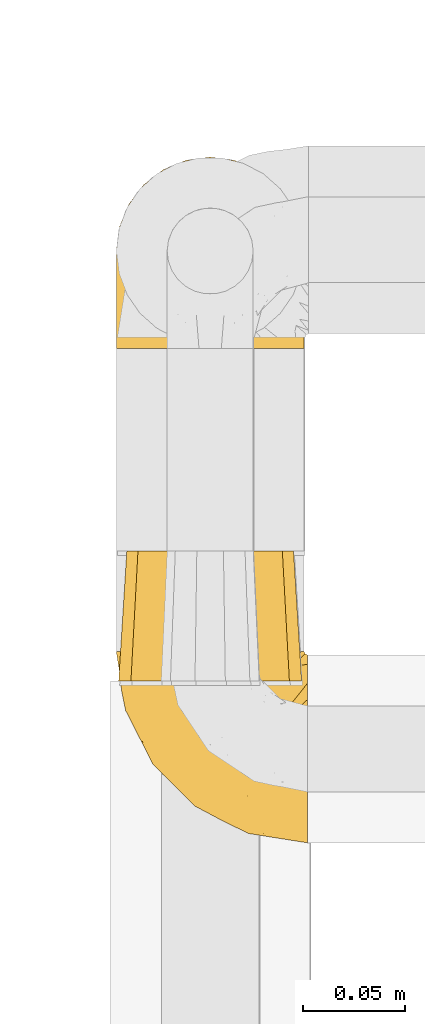
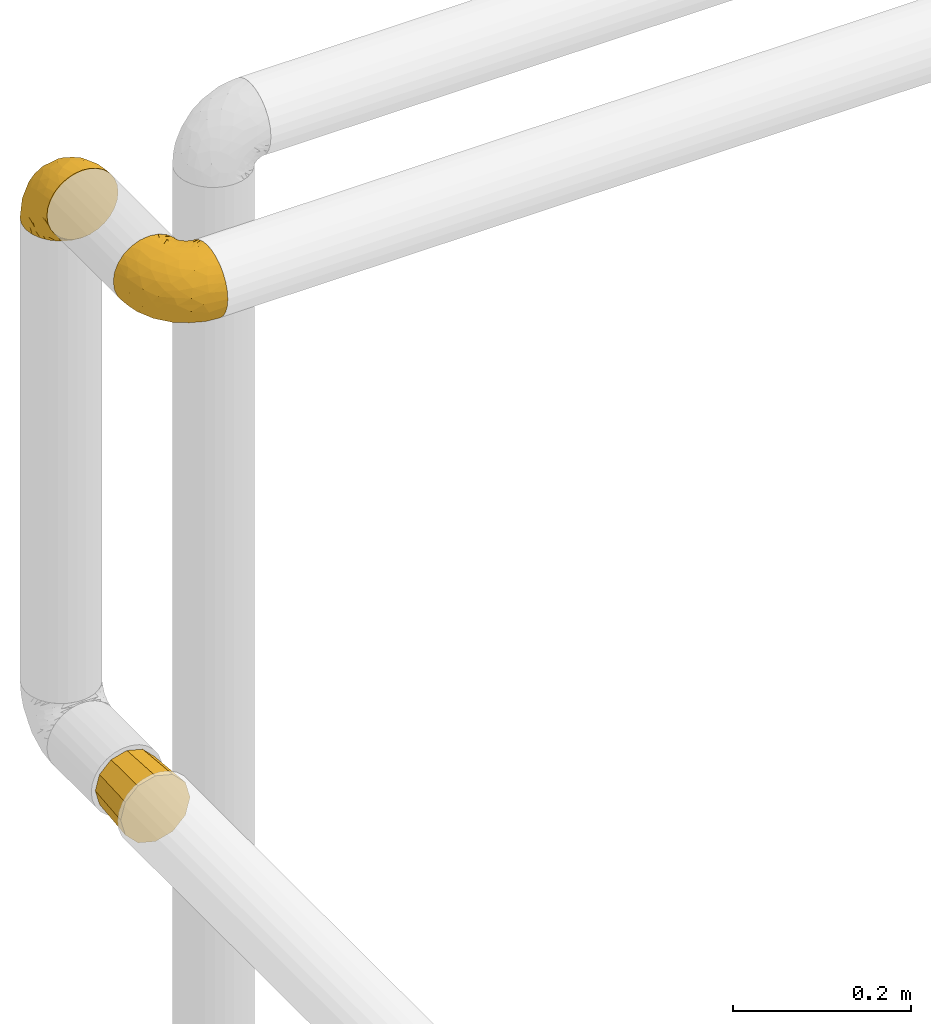
# One storey, part 131 of 827: 3 coverings.
"""IFC2X3 building model written with IfcOpenShell, lengths in millimetres."""

import ifcopenshell
import ifcopenshell.guid

model = None  # the IFC model being written
_history = None  # IfcOwnerHistory: only IFC2X3 demands one
_inside = {}  # id of a spatial element -> (the spatial element, [elements in it])
_under = {}  # id of a project, library or spatial element -> (it, [spatial elements below it])
_declared = {}  # id of a project -> (the project, [libraries it declares])
_typed = {}  # id of a type object -> (the type object, [elements of that type])
_made_of = {}  # id of a material, layer set ... -> (it, [elements and type objects made of it])


def new_model(schema):
    """Start an empty IFC model of exactly this schema.

    Asked for "IFC4X3", IfcOpenShell would pick the latest addendum, in which some entities
    have other attributes; the version numbers below select the first issue.
    IFC2X3 requires an IfcOwnerHistory on every rooted entity: one is made here for all.
    """
    global model, _history
    if schema == "IFC4X3":
        model = ifcopenshell.file(schema_version=(4, 3, 0, 0))
    else:
        model = ifcopenshell.file(schema=schema)
    _inside.clear()
    _under.clear()
    _declared.clear()
    _typed.clear()
    _made_of.clear()
    _history = None
    if model.schema == "IFC2X3":
        org = make("IfcOrganization", Name="unknown")
        user = make(
            "IfcPersonAndOrganization",
            ThePerson=make("IfcPerson", FamilyName="unknown"),
            TheOrganization=org,
        )
        app = make(
            "IfcApplication",
            ApplicationDeveloper=org,
            Version="unknown",
            ApplicationFullName="unknown",
            ApplicationIdentifier="unknown",
        )
        _history = make(
            "IfcOwnerHistory",
            OwningUser=user,
            OwningApplication=app,
            ChangeAction="ADDED",
            CreationDate=0,
        )
    return model


def make(cls, **values):
    """One entity of the class cls with the attributes given. An attribute that is None is left unset."""
    return model.create_entity(
        cls, **{name: value for name, value in values.items() if value is not None}
    )


def entity(cls, *values):
    """Any entity or typed value of the class cls, its attributes in the order of the schema. None: left unset."""
    e = model.create_entity(cls)
    for i, value in enumerate(values):
        if value is not None:
            e[i] = value
    return e


def rooted(cls, **values):
    """An entity with a GlobalId (a new one), such as an element, a storey or a relation."""
    return make(cls, GlobalId=ifcopenshell.guid.new(), OwnerHistory=_history, **values)


def si_unit(unit_type, name, prefix=None):
    """IfcSIUnit, for example si_unit("LENGTHUNIT", "METRE", prefix="MILLI")."""
    return make("IfcSIUnit", UnitType=unit_type, Prefix=prefix, Name=name)


def converted_unit(unit_type, name, factor, base, dimensions=None, offset=None):
    """IfcConversionBasedUnit, such as the inch: factor (a typed value) times the base unit."""
    return make(
        "IfcConversionBasedUnit"
        if offset is None
        else "IfcConversionBasedUnitWithOffset",
        ConversionOffset=offset,
        Dimensions=None
        if dimensions is None
        else entity("IfcDimensionalExponents", *dimensions),
        UnitType=unit_type,
        Name=name,
        ConversionFactor=make(
            "IfcMeasureWithUnit", ValueComponent=factor, UnitComponent=base
        ),
    )


def derived_unit(unit_type, elements):
    """IfcDerivedUnit: a product of units, each with its exponent."""
    return make(
        "IfcDerivedUnit",
        Elements=[
            make("IfcDerivedUnitElement", Unit=unit, Exponent=power)
            for unit, power in elements
        ],
        UnitType=unit_type,
    )


def assignment(units):
    """IfcUnitAssignment: the units of a project."""
    return None if units is None else make("IfcUnitAssignment", Units=units)


def point(xyz):
    """IfcCartesianPoint."""
    return None if xyz is None else make("IfcCartesianPoint", Coordinates=xyz)


def direction(xyz):
    """IfcDirection."""
    return None if xyz is None else make("IfcDirection", DirectionRatios=xyz)


def frame(location, z_axis=None, x_axis=None):
    """IfcAxis2Placement3D, a coordinate frame: its origin and axes. An axis left out is left unset."""
    return make(
        "IfcAxis2Placement3D",
        Location=point(location),
        Axis=direction(z_axis),
        RefDirection=direction(x_axis),
    )


def origin():
    """The frame at (0, 0, 0) with its axes left unset."""
    return frame((0.0, 0.0, 0.0))


def place(relative_to, where):
    """IfcLocalPlacement: puts the frame where relative to a parent placement (None: the world)."""
    return make(
        "IfcLocalPlacement", PlacementRelTo=relative_to, RelativePlacement=where
    )


def context(
    kind, dimensions, precision=None, world=None, true_north=None, identifier=None
):
    """IfcGeometricRepresentationContext, for example the 3D "Model" context."""
    return make(
        "IfcGeometricRepresentationContext",
        ContextIdentifier=identifier,
        ContextType=kind,
        CoordinateSpaceDimension=dimensions,
        Precision=precision,
        WorldCoordinateSystem=world,
        TrueNorth=true_north,
    )


def subcontext(parent, identifier, kind, view, scale=None):
    """IfcGeometricRepresentationSubContext, for example "Body" below "Model"."""
    return make(
        "IfcGeometricRepresentationSubContext",
        ContextIdentifier=identifier,
        ContextType=kind,
        ParentContext=parent,
        TargetScale=scale,
        TargetView=view,
    )


def project(units=None, contexts=None):
    """IfcProject with its units and contexts."""
    return rooted(
        "IfcProject",
        Name="project",
        RepresentationContexts=contexts,
        UnitsInContext=assignment(units),
    )


def spatial(cls, under=None, at=None, **own):
    """A site, building, storey or space (cls), placed at a placement, below another one or the project."""
    s = rooted(cls, ObjectPlacement=at, **own)
    if under is not None:
        _under.setdefault(under.id(), (under, []))[1].append(s)
    return s


def faces_of(points, faces, orient=None, outer=None):
    """IfcFace entities. A face is a list of loops; a loop is a list of indices into points, from 0.

    orient and outer hold one flag for each loop. By default every Orientation is true, the
    first loop of a face is its IfcFaceOuterBound and the others are IfcFaceBound.
    """
    made = []
    for i, loops in enumerate(faces):
        bounds = []
        for j, loop in enumerate(loops):
            is_outer = j == 0 if outer is None else outer[i][j]
            bounds.append(
                make(
                    "IfcFaceOuterBound" if is_outer else "IfcFaceBound",
                    Bound=make("IfcPolyLoop", Polygon=[points[k] for k in loop]),
                    Orientation=True if orient is None else orient[i][j],
                )
            )
        made.append(make("IfcFace", Bounds=bounds))
    return made


def faceted_brep(points, faces, orient=None, outer=None, voids=None):
    """IfcFacetedBrep: a solid bounded by flat faces; with voids (closed shells), ...WithVoids."""
    shared = [point(p) for p in points]
    hull = make("IfcClosedShell", CfsFaces=faces_of(shared, faces, orient, outer))
    if voids is None:
        return make("IfcFacetedBrep", Outer=hull)
    return make(
        "IfcFacetedBrepWithVoids",
        Outer=hull,
        Voids=[
            make(cls, CfsFaces=faces_of(shared, fs, o, b)) for cls, fs, o, b in voids
        ],
    )


def shape(context_of_items, identifier, shape_type, items):
    """IfcShapeRepresentation: the items that make up one representation, for example the "Body"."""
    return make(
        "IfcShapeRepresentation",
        ContextOfItems=context_of_items,
        RepresentationIdentifier=identifier,
        RepresentationType=shape_type,
        Items=items,
    )


def made_of(thing, what):
    """Note that an element or type object is made of a material, layer set ...; save() writes the relation."""
    if what is not None:
        _made_of.setdefault(what.id(), (what, []))[1].append(thing)
    return thing


def element(
    cls,
    number,
    at=None,
    inside=None,
    cuts=None,
    type_object=None,
    material=None,
    context=None,
    identifier="Body",
    shape_type=None,
    held_by="IfcProductDefinitionShape",
    body=None,
    shapes=None,
    **own,
):
    """One element of the class cls, such as IfcWall. Its Tag is "e" and its number.

    at: its placement. inside: the storey or other place that contains it. cuts: it is an
    opening in that element (IfcRelVoidsElement). A single representation is given by context,
    identifier, shape_type and body (its items); several are given by shapes. held_by: the class
    of the entity that holds the representations. save() writes the other relations.
    """
    e = rooted(cls, Tag="e%d" % number, ObjectPlacement=at, **own)
    if body is not None:
        shapes = [shape(context, identifier, shape_type, body)]
    if shapes is not None:
        e.Representation = make(held_by, Representations=shapes)
    if inside is not None:
        _inside.setdefault(inside.id(), (inside, []))[1].append(e)
    if cuts is not None:
        rooted(
            "IfcRelVoidsElement", RelatingBuildingElement=cuts, RelatedOpeningElement=e
        )
    if type_object is not None:
        _typed.setdefault(type_object.id(), (type_object, []))[1].append(e)
    return made_of(e, material)


def aggregate(whole, parts):
    """IfcRelAggregates: a whole, such as a stair, and the parts it consists of."""
    return rooted("IfcRelAggregates", RelatingObject=whole, RelatedObjects=parts)


def save(model, path):
    """Write the relations noted so far, then the file.

    IfcRelAggregates (storeys below a building ...), IfcRelContainedInSpatialStructure (elements
    in a storey), IfcRelDefinesByType, IfcRelAssociatesMaterial and IfcRelDeclares: one each for
    every whole, place, type object, material and project.
    """
    for whole, parts in _under.values():
        aggregate(whole, parts)
    for where, things in _inside.values():
        rooted(
            "IfcRelContainedInSpatialStructure",
            RelatedElements=things,
            RelatingStructure=where,
        )
    for kind, things in _typed.values():
        rooted("IfcRelDefinesByType", RelatedObjects=things, RelatingType=kind)
    for what, things in _made_of.values():
        rooted("IfcRelAssociatesMaterial", RelatedObjects=things, RelatingMaterial=what)
    for by, libraries in _declared.values():
        rooted("IfcRelDeclares", RelatingContext=by, RelatedDefinitions=libraries)
    model.write(path)


model = new_model("IFC2X3")

# Units and contexts
model_context = context("Model", 3, precision=0.01, world=origin(), true_north=direction((6.12303176911189e-17, 1.0)))
body_context = subcontext(model_context, "Body", "Model", "MODEL_VIEW")
ifc_project = project(units=[si_unit("LENGTHUNIT", "METRE", prefix="MILLI"), si_unit("AREAUNIT", "SQUARE_METRE"), si_unit("VOLUMEUNIT", "CUBIC_METRE"), converted_unit("PLANEANGLEUNIT", "DEGREE", entity("IfcRatioMeasure", 0.0174532925199433), si_unit("PLANEANGLEUNIT", "RADIAN"), dimensions=[0, 0, 0, 0, 0, 0, 0]), si_unit("MASSUNIT", "GRAM", prefix="KILO"), derived_unit("MASSDENSITYUNIT", [(si_unit("MASSUNIT", "GRAM", prefix="KILO"), 1), (si_unit("LENGTHUNIT", "METRE"), -3)]), derived_unit("MOMENTOFINERTIAUNIT", [(si_unit("LENGTHUNIT", "METRE"), 4)]), si_unit("TIMEUNIT", "SECOND"), si_unit("FREQUENCYUNIT", "HERTZ"), si_unit("THERMODYNAMICTEMPERATUREUNIT", "DEGREE_CELSIUS"), derived_unit("THERMALTRANSMITTANCEUNIT", [(si_unit("MASSUNIT", "GRAM", prefix="KILO"), 1), (si_unit("THERMODYNAMICTEMPERATUREUNIT", "KELVIN"), -1), (si_unit("TIMEUNIT", "SECOND"), -3)]), derived_unit("VOLUMETRICFLOWRATEUNIT", [(si_unit("LENGTHUNIT", "METRE"), 3), (si_unit("TIMEUNIT", "SECOND"), -1)]), derived_unit("MASSFLOWRATEUNIT", [(si_unit("MASSUNIT", "GRAM", prefix="KILO"), 1), (si_unit("TIMEUNIT", "SECOND"), -1)]), derived_unit("ROTATIONALFREQUENCYUNIT", [(si_unit("TIMEUNIT", "SECOND"), -1)]), si_unit("ELECTRICCURRENTUNIT", "AMPERE"), si_unit("ELECTRICVOLTAGEUNIT", "VOLT"), si_unit("POWERUNIT", "WATT"), si_unit("FORCEUNIT", "NEWTON", prefix="KILO"), si_unit("ILLUMINANCEUNIT", "LUX"), si_unit("LUMINOUSFLUXUNIT", "LUMEN"), si_unit("LUMINOUSINTENSITYUNIT", "CANDELA"), derived_unit("USERDEFINED", [(si_unit("MASSUNIT", "GRAM", prefix="KILO"), -1), (si_unit("LENGTHUNIT", "METRE"), -2), (si_unit("TIMEUNIT", "SECOND"), 3), (si_unit("LUMINOUSFLUXUNIT", "LUMEN"), 1)]), derived_unit("LINEARVELOCITYUNIT", [(si_unit("LENGTHUNIT", "METRE"), 1), (si_unit("TIMEUNIT", "SECOND"), -1)]), si_unit("PRESSUREUNIT", "PASCAL"), derived_unit("USERDEFINED", [(si_unit("LENGTHUNIT", "METRE"), -2), (si_unit("MASSUNIT", "GRAM", prefix="KILO"), 1), (si_unit("TIMEUNIT", "SECOND"), -2)]), derived_unit("LINEARFORCEUNIT", [(si_unit("MASSUNIT", "GRAM", prefix="KILO"), 1), (si_unit("LENGTHUNIT", "METRE"), 1), (si_unit("TIMEUNIT", "SECOND"), -2), (si_unit("LENGTHUNIT", "METRE"), -1)]), derived_unit("PLANARFORCEUNIT", [(si_unit("MASSUNIT", "GRAM", prefix="KILO"), 1), (si_unit("LENGTHUNIT", "METRE"), 1), (si_unit("TIMEUNIT", "SECOND"), -2), (si_unit("LENGTHUNIT", "METRE"), -2)])], contexts=[model_context])

# Site, building, storey
site_placement = place(None, origin())
site = spatial("IfcSite", under=ifc_project, at=site_placement, CompositionType="ELEMENT")
building_placement = place(site_placement, origin())
building = spatial("IfcBuilding", under=site, at=building_placement, CompositionType="ELEMENT")
storey_placement = place(building_placement, frame((0.0, 0.0, 28200.0)))
storey = spatial("IfcBuildingStorey", under=building, at=storey_placement, Name="08", CompositionType="ELEMENT", Elevation=28200.0)

# Coverings
covering_1_placement = place(storey_placement, frame((11957.67, 18958.31, 2950.4)))
element("IfcCovering", 1, at=covering_1_placement, inside=storey, Name=":ADSK_", ObjectType=":ADSK_", PredefinedType="INSULATION", context=body_context, shape_type="Brep", body=[
    faceted_brep([(83.91, 1.6, 78.41), (76.59, 1.6, 85.72), (67.83, 1.6, 91.22), (58.07, 1.6, 94.64), (47.8, 1.6, 95.8), (37.51, 1.6, 94.64), (27.74, 1.6, 91.22), (18.98, 1.6, 85.71), (11.67, 1.6, 78.39), (6.17, 1.6, 69.63), (2.75, 1.6, 59.87), (1.6, 1.6, 49.6), (2.06, 1.6, 45.45), (2.41, 1.6, 42.38), (2.75, 1.6, 39.31), (4.46, 1.6, 34.43), (6.17, 1.6, 29.54), (8.93, 1.6, 25.16), (11.68, 1.6, 20.78), (15.34, 1.6, 17.13), (19.0, 1.6, 13.47), (27.76, 1.6, 7.97), (32.64, 1.6, 6.26), (37.52, 1.6, 4.55), (47.8, 1.6, 3.4), (58.08, 1.6, 4.55), (62.96, 1.6, 6.26), (67.85, 1.6, 7.97), (76.61, 1.6, 13.48), (80.26, 1.6, 17.14), (83.92, 1.6, 20.8), (86.67, 1.6, 25.18), (89.42, 1.6, 29.56), (91.13, 1.6, 34.44), (92.84, 1.6, 39.32), (93.18, 1.6, 42.39), (93.53, 1.6, 45.45), (94.0, 1.6, 49.6), (92.84, 1.6, 59.88), (89.42, 1.6, 69.65), (47.8, 3.4, 1.6), (35.84, 4.97, 1.6), (24.7, 9.58, 1.6), (19.91, 13.26, 1.6), (15.13, 16.93, 1.6), (11.46, 21.71, 1.6), (7.78, 26.5, 1.6), (5.48, 32.07, 1.6), (3.17, 37.64, 1.6), (2.69, 41.25, 1.6), (2.42, 43.34, 1.6), (2.14, 45.42, 1.6), (1.6, 49.6, 1.6), (3.17, 61.55, 1.6), (7.78, 72.7, 1.6), (15.13, 82.26, 1.6), (24.7, 89.61, 1.6), (35.84, 94.22, 1.6), (47.8, 95.8, 1.6), (59.75, 94.22, 1.6), (70.9, 89.61, 1.6), (80.46, 82.26, 1.6), (87.81, 72.7, 1.6), (92.42, 61.55, 1.6), (94.0, 49.6, 1.6), (93.45, 45.42, 1.6), (92.9, 41.25, 1.6), (92.42, 37.64, 1.6), (90.11, 32.07, 1.6), (87.81, 26.5, 1.6), (84.13, 21.71, 1.6), (80.46, 16.93, 1.6), (75.68, 13.26, 1.6), (70.9, 9.58, 1.6), (59.75, 4.97, 1.6), (71.98, 81.55, 36.81), (63.6, 90.4, 23.28), (59.72, 83.0, 45.8), (47.8, 91.18, 30.7), (55.16, 93.13, 21.2), (47.8, 94.0, 12.96), (63.76, 66.19, 66.19), (72.22, 70.92, 54.51), (74.18, 85.95, 17.98), (92.52, 49.74, 36.69), (94.0, 35.54, 35.54), (94.0, 38.14, 31.64), (94.0, 40.74, 27.75), (94.0, 43.34, 23.86), (94.0, 45.94, 19.96), (82.14, 77.59, 22.8), (80.34, 71.17, 42.67), (87.52, 65.81, 33.21), (79.59, 59.03, 59.45), (78.25, 45.85, 71.5), (85.01, 45.79, 62.66), (90.25, 41.42, 54.5), (93.2, 34.51, 47.57), (87.23, 56.04, 48.81), (85.55, 15.15, 74.98), (93.0, 56.51, 18.7), (89.31, 68.39, 15.75), (61.31, 23.33, 91.17), (56.86, 42.86, 85.28), (68.34, 39.42, 82.58), (65.71, 53.58, 75.78), (56.99, 59.17, 74.98), (72.15, 59.06, 67.27), (70.34, 22.63, 87.38), (78.36, 20.55, 82.04), (47.8, 12.96, 94.0), (47.8, 56.96, 77.8), (47.8, 67.38, 67.38), (93.06, 18.72, 56.2), (94.0, 5.33, 48.85), (94.0, 9.07, 48.11), (94.0, 11.79, 47.57), (94.0, 14.51, 47.03), (94.0, 17.24, 46.48), (94.0, 19.96, 45.94), (89.88, 21.03, 65.78), (94.0, 46.48, 17.24), (94.0, 47.03, 14.51), (94.0, 47.57, 11.79), (94.0, 48.11, 9.07), (94.0, 48.48, 7.2), (94.0, 48.85, 5.33), (47.8, 30.7, 91.18), (94.0, 23.86, 43.34), (94.0, 27.75, 40.74), (94.0, 31.64, 38.14), (83.7, 31.26, 72.73), (47.8, 77.8, 56.96), (55.9, 72.75, 62.23), (47.8, 43.83, 84.49), (47.8, 84.49, 43.83), (81.75, 14.58, 12.05), (86.43, 16.17, 18.95), (79.8, 10.82, 13.02), (69.84, 4.64, 8.34), (79.5, 7.71, 14.63), (88.08, 25.13, 11.09), (91.6, 32.66, 13.66), (92.93, 34.94, 20.08), (92.43, 36.76, 9.61), (93.24, 40.48, 9.48), (93.36, 39.25, 16.1), (57.25, 3.69, 3.42), (89.41, 13.99, 26.63), (92.89, 21.85, 33.72), (92.66, 17.93, 34.77), (79.58, 15.11, 6.75), (86.51, 21.14, 13.31), (86.29, 12.7, 21.11), (83.91, 7.21, 19.94), (90.94, 32.27, 8.67), (91.94, 25.68, 26.11), (91.98, 22.18, 29.3), (82.79, 18.79, 6.32), (93.16, 10.12, 39.92), (88.76, 9.47, 27.05), (73.94, 10.45, 6.04), (91.89, 11.29, 34.4), (47.8, 2.87, 2.87), (92.22, 31.16, 20.92), (88.56, 6.31, 27.43), (87.72, 25.62, 7.54), (88.33, 21.18, 18.45), (92.18, 28.81, 23.88), (71.78, 7.45, 7.77), (7.27, 21.17, 18.43), (9.17, 16.17, 18.93), (3.66, 25.69, 26.08), (1.6, 48.11, 9.07), (1.6, 48.85, 5.33), (1.6, 47.03, 14.51), (1.6, 47.57, 11.79), (38.35, 3.69, 3.42), (23.84, 7.44, 7.76), (1.6, 14.51, 47.03), (1.6, 11.79, 47.57), (1.6, 5.33, 48.85), (1.6, 9.07, 48.11), (16.1, 7.71, 14.62), (6.84, 9.47, 27.03), (2.66, 34.94, 20.08), (3.37, 31.16, 20.92), (1.6, 40.74, 27.75), (1.6, 38.14, 31.64), (12.8, 18.79, 6.33), (3.16, 36.76, 9.61), (2.35, 40.48, 9.48), (25.77, 4.63, 8.33), (9.09, 21.14, 13.3), (16.02, 15.11, 6.74), (13.85, 14.58, 12.04), (1.6, 43.34, 23.86), (1.6, 45.94, 19.96), (2.23, 39.25, 16.1), (11.69, 7.21, 19.93), (9.31, 12.69, 21.1), (2.43, 10.14, 39.92), (2.71, 21.81, 33.68), (3.61, 22.19, 29.28), (6.18, 14.0, 26.62), (6.77, 6.66, 27.87), (2.93, 17.92, 34.75), (21.66, 10.45, 6.04), (1.6, 31.64, 38.14), (16.09, 10.64, 12.79), (3.7, 11.31, 34.41), (1.6, 19.96, 45.94), (1.6, 23.86, 43.34), (1.6, 27.75, 40.74), (3.99, 32.66, 13.66), (1.6, 46.48, 17.24), (4.65, 32.27, 8.67), (7.51, 25.13, 11.09), (1.6, 35.54, 35.54), (3.43, 28.77, 23.83), (9.46, 23.36, 6.03), (1.6, 17.24, 46.48), (2.4, 47.58, 34.52), (40.43, 93.13, 21.2), (13.57, 77.44, 23.82), (11.3, 66.78, 41.32), (18.65, 71.68, 47.62), (27.26, 74.96, 52.66), (23.61, 81.55, 36.81), (3.07, 36.7, 49.75), (2.69, 56.9, 19.07), (35.87, 83.0, 45.8), (31.99, 90.4, 23.28), (6.71, 67.83, 21.35), (21.41, 85.95, 17.98), (27.24, 39.41, 82.57), (34.26, 23.33, 91.17), (38.73, 42.87, 85.27), (26.97, 53.92, 73.89), (31.83, 66.19, 66.19), (23.4, 64.12, 62.43), (6.91, 33.13, 63.53), (3.4, 23.1, 58.45), (5.84, 16.98, 67.16), (35.73, 55.72, 76.72), (39.69, 72.75, 62.22), (17.6, 23.77, 81.54), (10.38, 18.41, 74.8), (20.6, 43.7, 75.83), (5.36, 54.53, 41.45), (24.84, 17.73, 88.2), (13.87, 38.98, 71.6), (9.06, 50.28, 56.23), (15.99, 59.02, 59.44)], [[[0, 1, 2, 3, 4, 5, 6, 7, 8, 9, 10, 11, 12, 13, 14, 15, 16, 17, 18, 19, 20, 21, 22, 23, 24, 25, 26, 27, 28, 29, 30, 31, 32, 33, 34, 35, 36, 37, 38, 39]], [[40, 41, 42, 43, 44, 45, 46, 47, 48, 49, 50, 51, 52, 53, 54, 55, 56, 57, 58, 59, 60, 61, 62, 63, 64, 65, 66, 67, 68, 69, 70, 71, 72, 73, 74]], [[75, 76, 77]], [[78, 79, 80]], [[77, 81, 82]], [[76, 75, 83]], [[84, 85, 86, 87, 88, 89]], [[90, 91, 92]], [[76, 60, 59]], [[93, 94, 95]], [[90, 62, 61]], [[83, 61, 60]], [[96, 97, 84]], [[98, 93, 95]], [[0, 39, 99]], [[100, 84, 89]], [[62, 101, 63]], [[2, 102, 3]], [[92, 84, 100]], [[103, 102, 104]], [[103, 105, 106]], [[93, 107, 94]], [[1, 108, 2]], [[92, 101, 90]], [[108, 1, 109]], [[102, 110, 3]], [[93, 82, 107]], [[102, 108, 104]], [[111, 106, 112]], [[109, 0, 99]], [[113, 37, 114, 115, 116, 117, 118, 119]], [[120, 38, 113]], [[100, 89, 121, 122, 123, 124, 125, 126, 64]], [[127, 102, 103]], [[97, 119, 128, 129, 130, 85]], [[99, 120, 131]], [[132, 133, 77]], [[59, 80, 79]], [[1, 0, 109]], [[98, 84, 92]], [[94, 109, 131]], [[120, 39, 38]], [[93, 91, 82]], [[104, 94, 105]], [[97, 113, 119]], [[95, 120, 96]], [[83, 90, 61]], [[91, 93, 98]], [[64, 63, 100]], [[100, 63, 101]], [[77, 76, 79]], [[133, 106, 81]], [[84, 97, 85]], [[113, 96, 120]], [[113, 97, 96]], [[37, 113, 38]], [[110, 102, 127]], [[110, 4, 3]], [[103, 111, 134, 127]], [[90, 75, 91]], [[82, 81, 107]], [[91, 75, 82]], [[77, 82, 75]], [[76, 83, 60]], [[90, 83, 75]], [[105, 107, 81]], [[94, 131, 95]], [[105, 94, 107]], [[109, 94, 104]], [[120, 95, 131]], [[98, 95, 96]], [[84, 98, 96]], [[98, 92, 91]], [[106, 105, 81]], [[103, 104, 105]], [[112, 106, 133]], [[103, 106, 111]], [[112, 133, 132]], [[81, 77, 133]], [[77, 78, 135, 132]], [[120, 99, 39]], [[109, 99, 131]], [[59, 58, 80]], [[59, 79, 76]], [[90, 101, 62]], [[100, 101, 92]], [[2, 108, 102]], [[109, 104, 108]], [[78, 77, 79]], [[136, 137, 138]], [[27, 139, 140]], [[141, 142, 143]], [[144, 145, 121]], [[146, 89, 88]], [[147, 139, 25]], [[148, 149, 150]], [[136, 151, 152]], [[147, 40, 74]], [[24, 147, 25]], [[140, 153, 154]], [[33, 116, 34]], [[73, 72, 151]], [[114, 37, 36, 35, 34, 116, 115]], [[146, 155, 144]], [[156, 85, 130]], [[157, 149, 148]], [[151, 158, 152]], [[117, 33, 159]], [[29, 154, 160]], [[161, 74, 73]], [[162, 128, 119]], [[66, 65, 64, 126, 125, 124, 123, 122, 67]], [[163, 147, 24]], [[27, 140, 28]], [[149, 129, 150]], [[139, 27, 26, 25]], [[68, 144, 69]], [[129, 128, 150]], [[164, 87, 86]], [[130, 129, 149]], [[122, 145, 67]], [[154, 153, 148]], [[162, 119, 159]], [[165, 30, 160]], [[150, 160, 148]], [[128, 162, 150]], [[30, 165, 31]], [[145, 144, 68]], [[89, 146, 144]], [[87, 164, 143]], [[166, 155, 142]], [[88, 87, 143]], [[162, 160, 150]], [[160, 30, 29]], [[154, 29, 28]], [[140, 154, 28]], [[160, 154, 148]], [[140, 137, 153]], [[157, 148, 153]], [[156, 130, 157]], [[153, 137, 157]], [[157, 137, 156]], [[167, 137, 136]], [[168, 85, 156]], [[152, 168, 167]], [[167, 168, 156]], [[164, 152, 141]], [[71, 158, 72]], [[152, 167, 136]], [[88, 142, 146]], [[144, 155, 69]], [[146, 142, 155]], [[70, 166, 71]], [[142, 141, 166]], [[70, 69, 155]], [[141, 158, 71]], [[161, 73, 151]], [[138, 137, 140]], [[161, 136, 169]], [[136, 161, 151]], [[74, 161, 169]], [[152, 158, 141]], [[151, 72, 158]], [[168, 152, 164]], [[137, 167, 156]], [[164, 86, 168]], [[85, 168, 86]], [[116, 33, 117]], [[130, 149, 157]], [[67, 145, 68]], [[121, 89, 144]], [[145, 122, 121]], [[40, 147, 163]], [[169, 147, 74]], [[159, 33, 32]], [[162, 159, 32]], [[159, 119, 118, 117]], [[139, 147, 169]], [[139, 169, 138]], [[162, 32, 31]], [[141, 143, 164]], [[88, 143, 142]], [[71, 166, 141]], [[155, 166, 70]], [[139, 138, 140]], [[169, 136, 138]], [[160, 162, 165]], [[162, 31, 165]], [[170, 171, 172]], [[173, 174, 52, 51, 50, 49, 48, 175, 176]], [[177, 178, 41]], [[179, 15, 180]], [[12, 11, 181, 182, 180, 14, 13]], [[183, 21, 20]], [[19, 18, 184]], [[185, 186, 187]], [[186, 188, 187]], [[43, 189, 44]], [[190, 191, 47]], [[23, 22, 21, 192]], [[193, 194, 195]], [[40, 163, 177]], [[196, 197, 198]], [[24, 23, 177]], [[199, 200, 183]], [[201, 15, 179]], [[47, 46, 190]], [[202, 203, 204]], [[203, 172, 171]], [[205, 206, 184]], [[207, 41, 178]], [[16, 15, 201]], [[14, 180, 15]], [[204, 203, 200]], [[208, 203, 202]], [[163, 24, 177]], [[48, 47, 191]], [[198, 197, 190]], [[199, 184, 204]], [[171, 195, 209]], [[210, 211, 212]], [[206, 212, 213]], [[205, 17, 210]], [[184, 206, 204]], [[210, 212, 206]], [[185, 196, 214]], [[190, 215, 191]], [[216, 45, 214]], [[186, 217, 193]], [[190, 216, 198]], [[199, 20, 19]], [[196, 185, 187]], [[199, 183, 20]], [[184, 199, 19]], [[199, 204, 200]], [[206, 202, 204]], [[171, 183, 200]], [[203, 208, 172]], [[172, 208, 218]], [[171, 200, 203]], [[218, 188, 219]], [[195, 170, 193]], [[217, 186, 185]], [[193, 219, 186]], [[193, 170, 219]], [[207, 194, 42]], [[217, 220, 189]], [[216, 190, 46]], [[214, 196, 198]], [[44, 220, 45]], [[214, 198, 216]], [[216, 46, 45]], [[214, 45, 220]], [[42, 194, 43]], [[189, 193, 217]], [[207, 195, 194]], [[209, 195, 178]], [[41, 207, 42]], [[195, 207, 178]], [[43, 194, 189]], [[193, 189, 194]], [[171, 170, 195]], [[170, 172, 219]], [[218, 219, 172]], [[188, 186, 219]], [[206, 213, 202]], [[208, 202, 213]], [[201, 210, 16]], [[215, 190, 197]], [[215, 175, 191]], [[175, 48, 191]], [[201, 179, 221, 211]], [[210, 201, 211]], [[23, 192, 177]], [[40, 177, 41]], [[178, 177, 192]], [[21, 183, 192]], [[209, 192, 183]], [[205, 18, 17]], [[17, 16, 210]], [[217, 185, 214]], [[189, 220, 44]], [[214, 220, 217]], [[192, 209, 178]], [[171, 209, 183]], [[206, 205, 210]], [[18, 205, 184]], [[222, 197, 196, 187, 188, 218]], [[57, 223, 80]], [[224, 225, 226]], [[226, 227, 228]], [[229, 218, 208, 213, 212, 211]], [[230, 52, 174, 173, 176, 175, 215, 197]], [[231, 232, 228]], [[231, 78, 223]], [[223, 57, 232]], [[224, 233, 225]], [[233, 54, 53]], [[234, 232, 56]], [[56, 55, 234]], [[234, 224, 228]], [[235, 236, 237]], [[224, 55, 54]], [[238, 239, 240]], [[52, 230, 53]], [[241, 242, 243]], [[239, 244, 245]], [[11, 10, 242]], [[236, 6, 5]], [[7, 246, 8]], [[8, 247, 9]], [[238, 248, 235]], [[222, 229, 249]], [[242, 211, 221, 179, 180, 182, 181, 11]], [[233, 53, 230]], [[111, 112, 244]], [[250, 6, 236]], [[247, 251, 241]], [[6, 250, 7]], [[127, 236, 110]], [[249, 229, 252]], [[247, 8, 246]], [[235, 246, 250]], [[236, 5, 110]], [[235, 244, 238]], [[237, 236, 127]], [[243, 9, 247]], [[252, 229, 241]], [[56, 232, 57]], [[222, 230, 197]], [[225, 249, 252]], [[249, 233, 230]], [[54, 233, 224]], [[231, 228, 227]], [[245, 132, 231]], [[249, 225, 233]], [[226, 225, 253]], [[235, 250, 236]], [[246, 7, 250]], [[251, 247, 246]], [[243, 247, 241]], [[248, 246, 235]], [[252, 251, 253]], [[229, 222, 218]], [[230, 222, 249]], [[5, 4, 110]], [[237, 127, 134, 111]], [[238, 244, 239]], [[224, 234, 55]], [[232, 234, 228]], [[242, 241, 229]], [[10, 9, 243]], [[211, 242, 229]], [[10, 243, 242]], [[80, 223, 78]], [[80, 58, 57]], [[231, 223, 232]], [[227, 240, 239]], [[224, 226, 228]], [[240, 226, 253]], [[227, 239, 245]], [[226, 240, 227]], [[251, 248, 253]], [[240, 253, 248]], [[244, 235, 237]], [[237, 111, 244]], [[132, 245, 112]], [[112, 245, 244]], [[135, 78, 231, 132]], [[227, 245, 231]], [[248, 238, 240]], [[246, 248, 251]], [[251, 252, 241]], [[225, 252, 253]]]),
])
covering_2_placement = place(storey_placement, frame((11957.67, 18715.18, 2952.2)))
element("IfcCovering", 2, at=covering_2_placement, inside=storey, Name=":ADSK_", ObjectType=":ADSK_", PredefinedType="INSULATION", context=body_context, shape_type="Brep", body=[
    faceted_brep([(95.8, 18.98, 83.91), (95.8, 11.67, 76.59), (95.8, 6.17, 67.83), (95.8, 2.75, 58.07), (95.8, 1.6, 47.8), (95.8, 2.75, 37.51), (95.8, 6.17, 27.74), (95.8, 11.68, 18.98), (95.8, 19.0, 11.67), (95.8, 27.76, 6.17), (95.8, 37.52, 2.75), (95.8, 47.8, 1.6), (95.8, 51.94, 2.06), (95.8, 55.01, 2.41), (95.8, 58.08, 2.75), (95.8, 62.96, 4.46), (95.8, 67.85, 6.17), (95.8, 72.23, 8.93), (95.8, 76.61, 11.68), (95.8, 80.26, 15.34), (95.8, 83.92, 19.0), (95.8, 89.42, 27.76), (95.8, 91.13, 32.64), (95.8, 92.84, 37.52), (95.8, 94.0, 47.8), (95.8, 92.84, 58.08), (95.8, 91.13, 62.96), (95.8, 89.42, 67.85), (95.8, 83.91, 76.61), (95.8, 80.25, 80.26), (95.8, 76.59, 83.92), (95.8, 72.21, 86.67), (95.8, 67.83, 89.42), (95.8, 62.95, 91.13), (95.8, 58.07, 92.84), (95.8, 55.0, 93.18), (95.8, 51.94, 93.53), (95.8, 47.8, 94.0), (95.8, 37.51, 92.84), (95.8, 27.74, 89.42), (94.0, 95.8, 47.8), (92.42, 95.8, 35.84), (87.81, 95.8, 24.7), (84.13, 95.8, 19.91), (80.46, 95.8, 15.13), (75.68, 95.8, 11.46), (70.9, 95.8, 7.78), (65.32, 95.8, 5.48), (59.75, 95.8, 3.17), (56.14, 95.8, 2.69), (54.06, 95.8, 2.42), (51.97, 95.8, 2.14), (47.8, 95.8, 1.6), (35.84, 95.8, 3.17), (24.7, 95.8, 7.78), (15.13, 95.8, 15.13), (7.78, 95.8, 24.7), (3.17, 95.8, 35.84), (1.6, 95.8, 47.8), (3.17, 95.8, 59.75), (7.78, 95.8, 70.9), (15.13, 95.8, 80.46), (24.7, 95.8, 87.81), (35.84, 95.8, 92.42), (47.8, 95.8, 94.0), (51.97, 95.8, 93.45), (56.14, 95.8, 92.9), (59.75, 95.8, 92.42), (65.32, 95.8, 90.11), (70.9, 95.8, 87.81), (75.68, 95.8, 84.13), (80.46, 95.8, 80.46), (84.13, 95.8, 75.68), (87.81, 95.8, 70.9), (92.42, 95.8, 59.75), (15.84, 60.58, 71.98), (6.99, 74.11, 63.6), (14.39, 51.59, 59.72), (6.21, 66.69, 47.8), (4.26, 76.19, 55.16), (3.39, 84.43, 47.8), (31.2, 31.2, 63.76), (26.47, 42.88, 72.22), (11.44, 79.41, 74.18), (47.66, 60.7, 92.52), (61.85, 61.85, 94.0), (59.25, 65.75, 94.0), (56.65, 69.64, 94.0), (54.05, 73.53, 94.0), (51.45, 77.43, 94.0), (19.8, 74.59, 82.14), (26.22, 54.72, 80.34), (31.58, 64.18, 87.52), (38.36, 37.94, 79.59), (51.54, 25.89, 78.25), (51.6, 34.73, 85.01), (55.97, 42.89, 90.25), (62.88, 49.83, 93.2), (41.35, 48.58, 87.23), (82.24, 22.41, 85.55), (40.88, 78.69, 93.0), (29.0, 81.64, 89.31), (74.06, 6.22, 61.31), (54.53, 12.11, 56.86), (57.98, 14.81, 68.34), (43.81, 21.61, 65.71), (38.22, 22.41, 56.99), (38.33, 30.12, 72.15), (74.76, 10.01, 70.34), (76.85, 15.36, 78.36), (84.43, 3.39, 47.8), (40.43, 19.59, 47.8), (30.01, 30.01, 47.8), (78.67, 41.19, 93.06), (92.06, 48.54, 94.0), (88.32, 49.28, 94.0), (85.6, 49.82, 94.0), (82.88, 50.37, 94.0), (80.15, 50.91, 94.0), (77.43, 51.45, 94.0), (76.36, 31.61, 89.88), (50.91, 80.15, 94.0), (50.37, 82.88, 94.0), (49.82, 85.6, 94.0), (49.28, 88.32, 94.0), (48.91, 90.19, 94.0), (48.54, 92.06, 94.0), (66.69, 6.21, 47.8), (73.53, 54.05, 94.0), (69.64, 56.65, 94.0), (65.75, 59.25, 94.0), (66.13, 24.66, 83.7), (19.59, 40.43, 47.8), (24.64, 35.17, 55.9), (53.56, 12.9, 47.8), (12.9, 53.56, 47.8), (82.81, 85.34, 81.75), (81.22, 78.44, 86.43), (86.57, 84.37, 79.8), (92.75, 89.05, 69.84), (89.68, 82.76, 79.5), (72.26, 86.31, 88.08), (64.73, 83.73, 91.6), (62.45, 77.31, 92.93), (60.63, 87.78, 92.43), (56.91, 87.91, 93.24), (58.14, 81.29, 93.36), (93.7, 93.97, 57.25), (83.4, 70.76, 89.41), (75.54, 63.67, 92.89), (79.46, 62.62, 92.66), (82.28, 90.64, 79.58), (76.25, 84.08, 86.51), (90.18, 77.45, 83.91), (87.92, 70.34, 88.76), (65.12, 88.72, 90.94), (71.71, 71.28, 91.94), (75.21, 68.09, 91.98), (78.6, 91.07, 82.79), (87.27, 57.47, 93.16), (86.94, 91.35, 73.94), (86.1, 62.99, 91.89), (94.52, 94.52, 47.8), (66.23, 76.47, 92.22), (84.69, 76.28, 86.29), (91.08, 69.96, 88.56), (71.77, 89.86, 87.72), (76.21, 78.94, 88.33), (68.59, 73.51, 92.18), (89.94, 89.62, 71.78), (76.22, 78.96, 7.27), (81.22, 78.46, 9.17), (71.7, 71.31, 3.66), (49.28, 88.32, 1.6), (48.54, 92.06, 1.6), (50.37, 82.88, 1.6), (49.82, 85.6, 1.6), (93.7, 93.97, 38.35), (89.95, 89.63, 23.84), (82.88, 50.37, 1.6), (85.6, 49.82, 1.6), (92.06, 48.54, 1.6), (88.32, 49.28, 1.6), (89.68, 82.77, 16.1), (87.92, 70.36, 6.84), (62.45, 77.31, 2.66), (66.24, 76.47, 3.37), (56.65, 69.64, 1.6), (59.25, 65.75, 1.6), (78.6, 91.06, 12.8), (60.63, 87.78, 3.16), (56.91, 87.91, 2.35), (92.76, 89.06, 25.77), (76.25, 84.09, 9.09), (82.28, 90.65, 16.02), (82.81, 85.35, 13.85), (54.05, 73.53, 1.6), (51.45, 77.43, 1.6), (58.14, 81.29, 2.23), (90.18, 77.46, 11.69), (84.7, 76.29, 9.31), (87.25, 57.47, 2.43), (75.58, 63.71, 2.71), (75.2, 68.11, 3.61), (83.39, 70.77, 6.18), (90.73, 69.52, 6.77), (79.47, 62.64, 2.93), (86.94, 91.35, 21.66), (65.75, 59.25, 1.6), (86.75, 84.6, 16.09), (86.08, 62.98, 3.7), (77.43, 51.45, 1.6), (73.53, 54.05, 1.6), (69.64, 56.65, 1.6), (64.73, 83.73, 3.99), (50.91, 80.15, 1.6), (65.12, 88.72, 4.65), (72.26, 86.3, 7.51), (61.85, 61.85, 1.6), (68.62, 73.56, 3.43), (74.03, 91.36, 9.46), (80.15, 50.91, 1.6), (49.81, 62.87, 2.4), (4.26, 76.19, 40.43), (19.95, 73.57, 13.57), (30.61, 56.07, 11.3), (25.71, 49.77, 18.65), (22.43, 44.73, 27.26), (15.85, 60.58, 23.61), (60.69, 47.64, 3.07), (40.49, 78.32, 2.69), (14.39, 51.59, 35.87), (6.99, 74.11, 31.99), (29.56, 76.04, 6.71), (11.45, 79.41, 21.41), (57.98, 14.82, 27.24), (74.06, 6.22, 34.26), (54.52, 12.12, 38.73), (43.47, 23.51, 26.97), (31.2, 31.2, 31.83), (33.27, 34.96, 23.4), (64.26, 33.86, 6.91), (74.29, 38.94, 3.4), (80.41, 30.23, 5.84), (24.64, 35.17, 39.69), (73.62, 15.85, 17.6), (78.98, 22.59, 10.38), (53.69, 21.56, 20.6), (42.86, 55.94, 5.36), (41.67, 20.67, 35.73), (79.66, 9.19, 24.84), (58.41, 25.79, 13.87), (47.11, 41.16, 9.06), (38.37, 37.95, 15.99)], [[[0, 1, 2, 3, 4, 5, 6, 7, 8, 9, 10, 11, 12, 13, 14, 15, 16, 17, 18, 19, 20, 21, 22, 23, 24, 25, 26, 27, 28, 29, 30, 31, 32, 33, 34, 35, 36, 37, 38, 39]], [[40, 41, 42, 43, 44, 45, 46, 47, 48, 49, 50, 51, 52, 53, 54, 55, 56, 57, 58, 59, 60, 61, 62, 63, 64, 65, 66, 67, 68, 69, 70, 71, 72, 73, 74]], [[75, 76, 77]], [[78, 79, 80]], [[77, 81, 82]], [[76, 75, 83]], [[84, 85, 86, 87, 88, 89]], [[90, 91, 92]], [[76, 60, 59]], [[93, 94, 95]], [[90, 62, 61]], [[83, 61, 60]], [[96, 97, 84]], [[98, 93, 95]], [[0, 39, 99]], [[100, 84, 89]], [[62, 101, 63]], [[2, 102, 3]], [[92, 84, 100]], [[103, 102, 104]], [[103, 105, 106]], [[93, 107, 94]], [[1, 108, 2]], [[92, 101, 90]], [[108, 1, 109]], [[102, 110, 3]], [[93, 82, 107]], [[102, 108, 104]], [[111, 106, 112]], [[109, 0, 99]], [[113, 37, 114, 115, 116, 117, 118, 119]], [[120, 38, 113]], [[100, 89, 121, 122, 123, 124, 125, 126, 64]], [[127, 102, 103]], [[97, 119, 128, 129, 130, 85]], [[99, 120, 131]], [[132, 133, 77]], [[59, 80, 79]], [[1, 0, 109]], [[98, 84, 92]], [[94, 109, 131]], [[120, 39, 38]], [[93, 91, 82]], [[104, 94, 105]], [[97, 113, 119]], [[95, 120, 96]], [[83, 90, 61]], [[91, 93, 98]], [[64, 63, 100]], [[100, 63, 101]], [[77, 76, 79]], [[133, 106, 81]], [[84, 97, 85]], [[113, 96, 120]], [[113, 97, 96]], [[37, 113, 38]], [[110, 102, 127]], [[110, 4, 3]], [[103, 111, 134, 127]], [[90, 75, 91]], [[82, 81, 107]], [[91, 75, 82]], [[77, 82, 75]], [[76, 83, 60]], [[90, 83, 75]], [[105, 107, 81]], [[94, 131, 95]], [[105, 94, 107]], [[109, 94, 104]], [[120, 95, 131]], [[98, 95, 96]], [[84, 98, 96]], [[98, 92, 91]], [[106, 105, 81]], [[103, 104, 105]], [[112, 106, 133]], [[103, 106, 111]], [[112, 133, 132]], [[81, 77, 133]], [[77, 78, 135, 132]], [[120, 99, 39]], [[109, 99, 131]], [[59, 58, 80]], [[59, 79, 76]], [[90, 101, 62]], [[100, 101, 92]], [[2, 108, 102]], [[109, 104, 108]], [[78, 77, 79]], [[136, 137, 138]], [[27, 139, 140]], [[141, 142, 143]], [[144, 145, 121]], [[146, 89, 88]], [[147, 139, 25]], [[148, 149, 150]], [[136, 151, 152]], [[147, 40, 74]], [[24, 147, 25]], [[153, 148, 154]], [[33, 116, 34]], [[73, 72, 151]], [[114, 37, 36, 35, 34, 116, 115]], [[146, 155, 144]], [[156, 85, 130]], [[157, 149, 148]], [[151, 158, 152]], [[117, 33, 159]], [[29, 153, 154]], [[160, 74, 73]], [[161, 128, 119]], [[66, 65, 64, 126, 125, 124, 123, 122, 67]], [[162, 147, 24]], [[27, 140, 28]], [[149, 129, 150]], [[139, 27, 26, 25]], [[68, 144, 69]], [[129, 128, 150]], [[163, 87, 86]], [[130, 129, 149]], [[122, 145, 67]], [[153, 164, 148]], [[161, 119, 159]], [[165, 30, 154]], [[150, 154, 148]], [[128, 161, 150]], [[30, 165, 31]], [[145, 144, 68]], [[89, 146, 144]], [[87, 163, 143]], [[166, 155, 142]], [[88, 87, 143]], [[161, 154, 150]], [[154, 30, 29]], [[29, 28, 153]], [[28, 140, 153]], [[164, 153, 140]], [[140, 137, 164]], [[157, 148, 164]], [[156, 130, 157]], [[164, 137, 157]], [[157, 137, 156]], [[167, 137, 136]], [[168, 85, 156]], [[152, 168, 167]], [[167, 168, 156]], [[163, 152, 141]], [[71, 158, 72]], [[152, 167, 136]], [[88, 142, 146]], [[144, 155, 69]], [[146, 142, 155]], [[70, 166, 71]], [[142, 141, 166]], [[70, 69, 155]], [[141, 158, 71]], [[160, 73, 151]], [[138, 137, 140]], [[160, 136, 169]], [[136, 160, 151]], [[74, 160, 169]], [[152, 158, 141]], [[151, 72, 158]], [[168, 152, 163]], [[137, 167, 156]], [[163, 86, 168]], [[85, 168, 86]], [[116, 33, 117]], [[130, 149, 157]], [[67, 145, 68]], [[121, 89, 144]], [[145, 122, 121]], [[40, 147, 162]], [[169, 147, 74]], [[159, 33, 32]], [[161, 159, 32]], [[159, 119, 118, 117]], [[139, 147, 169]], [[139, 169, 138]], [[161, 32, 31]], [[141, 143, 163]], [[88, 143, 142]], [[71, 166, 141]], [[155, 166, 70]], [[139, 138, 140]], [[169, 136, 138]], [[154, 161, 165]], [[161, 31, 165]], [[170, 171, 172]], [[173, 174, 52, 51, 50, 49, 48, 175, 176]], [[177, 178, 41]], [[179, 15, 180]], [[12, 11, 181, 182, 180, 14, 13]], [[183, 21, 20]], [[19, 18, 184]], [[185, 186, 187]], [[186, 188, 187]], [[43, 189, 44]], [[190, 191, 47]], [[23, 22, 21, 192]], [[193, 194, 195]], [[40, 162, 177]], [[196, 197, 198]], [[24, 23, 177]], [[199, 200, 183]], [[201, 15, 179]], [[47, 46, 190]], [[202, 203, 204]], [[203, 172, 171]], [[205, 206, 184]], [[207, 41, 178]], [[16, 15, 201]], [[14, 180, 15]], [[204, 203, 200]], [[208, 203, 202]], [[162, 24, 177]], [[48, 47, 191]], [[198, 197, 190]], [[199, 184, 204]], [[171, 195, 209]], [[210, 211, 212]], [[206, 212, 213]], [[205, 17, 210]], [[184, 206, 204]], [[210, 212, 206]], [[185, 196, 214]], [[190, 215, 191]], [[216, 45, 214]], [[186, 217, 193]], [[190, 216, 198]], [[199, 20, 19]], [[196, 185, 187]], [[199, 183, 20]], [[184, 199, 19]], [[199, 204, 200]], [[206, 202, 204]], [[171, 183, 200]], [[203, 208, 172]], [[172, 208, 218]], [[171, 200, 203]], [[218, 188, 219]], [[195, 170, 193]], [[217, 186, 185]], [[193, 219, 186]], [[193, 170, 219]], [[207, 194, 42]], [[217, 220, 189]], [[216, 190, 46]], [[214, 196, 198]], [[44, 220, 45]], [[214, 198, 216]], [[216, 46, 45]], [[214, 45, 220]], [[42, 194, 43]], [[189, 193, 217]], [[207, 195, 194]], [[209, 195, 178]], [[41, 207, 42]], [[195, 207, 178]], [[43, 194, 189]], [[193, 189, 194]], [[171, 170, 195]], [[170, 172, 219]], [[218, 219, 172]], [[188, 186, 219]], [[206, 213, 202]], [[208, 202, 213]], [[201, 210, 16]], [[215, 190, 197]], [[215, 175, 191]], [[175, 48, 191]], [[201, 179, 221, 211]], [[210, 201, 211]], [[23, 192, 177]], [[40, 177, 41]], [[178, 177, 192]], [[21, 183, 192]], [[209, 192, 183]], [[205, 18, 17]], [[17, 16, 210]], [[217, 185, 214]], [[189, 220, 44]], [[214, 220, 217]], [[192, 209, 178]], [[171, 209, 183]], [[206, 205, 210]], [[18, 205, 184]], [[222, 197, 196, 187, 188, 218]], [[57, 223, 80]], [[224, 225, 226]], [[226, 227, 228]], [[229, 218, 208, 213, 212, 211]], [[230, 52, 174, 173, 176, 175, 215, 197]], [[231, 232, 228]], [[231, 78, 223]], [[223, 57, 232]], [[224, 233, 225]], [[233, 54, 53]], [[234, 232, 56]], [[56, 55, 234]], [[234, 224, 228]], [[235, 236, 237]], [[224, 55, 54]], [[238, 239, 240]], [[52, 230, 53]], [[241, 242, 243]], [[227, 244, 231]], [[11, 10, 242]], [[236, 6, 5]], [[7, 245, 8]], [[8, 246, 9]], [[238, 247, 235]], [[222, 229, 248]], [[242, 211, 221, 179, 180, 182, 181, 11]], [[233, 53, 230]], [[111, 112, 249]], [[250, 6, 236]], [[246, 251, 241]], [[6, 250, 7]], [[127, 236, 110]], [[248, 229, 252]], [[246, 8, 245]], [[235, 245, 250]], [[236, 5, 110]], [[235, 249, 238]], [[237, 236, 127]], [[243, 9, 246]], [[252, 229, 241]], [[56, 232, 57]], [[222, 230, 197]], [[225, 248, 252]], [[248, 233, 230]], [[54, 233, 224]], [[231, 228, 227]], [[244, 132, 231]], [[248, 225, 233]], [[226, 225, 253]], [[235, 250, 236]], [[245, 7, 250]], [[251, 246, 245]], [[243, 246, 241]], [[247, 245, 235]], [[252, 251, 253]], [[229, 222, 218]], [[230, 222, 248]], [[5, 4, 110]], [[237, 127, 134, 111]], [[238, 249, 239]], [[224, 234, 55]], [[232, 234, 228]], [[242, 241, 229]], [[10, 9, 243]], [[211, 242, 229]], [[10, 243, 242]], [[80, 223, 78]], [[80, 58, 57]], [[231, 223, 232]], [[227, 240, 239]], [[224, 226, 228]], [[240, 226, 253]], [[227, 239, 244]], [[226, 240, 227]], [[251, 247, 253]], [[240, 253, 247]], [[249, 235, 237]], [[237, 111, 249]], [[112, 132, 244]], [[112, 244, 249]], [[78, 231, 132, 135]], [[249, 244, 239]], [[247, 238, 240]], [[245, 247, 251]], [[251, 252, 241]], [[225, 252, 253]]]),
])
covering_3_placement = place(storey_placement, frame((11958.87, 18796.42, 2223.69)))
element("IfcCovering", 3, at=covering_3_placement, inside=storey, Name=":ADSK_", ObjectType=":ADSK_", PredefinedType="INSULATION", context=body_context, shape_type="Brep", body=[
    faceted_brep([(69.1, 0.0, 85.57), (59.99, 0.0, 88.01), (46.6, 0.0, 91.6), (33.21, 0.0, 88.01), (24.1, 0.0, 85.57), (15.86, 0.0, 77.33), (7.62, 0.0, 69.1), (5.18, 0.0, 59.99), (1.6, 0.0, 46.6), (5.18, 0.0, 33.21), (7.62, 0.0, 24.1), (15.86, 0.0, 15.86), (24.1, 0.0, 7.62), (33.21, 0.0, 5.18), (46.6, 0.0, 1.6), (59.99, 0.0, 5.18), (69.1, 0.0, 7.62), (77.33, 0.0, 15.86), (85.57, 0.0, 24.1), (88.01, 0.0, 33.21), (91.6, 0.0, 46.6), (88.01, 0.0, 59.99), (85.57, 0.0, 69.1), (77.33, 0.0, 77.33), (87.6, 64.0, 46.6), (84.85, 64.0, 36.35), (82.1, 64.0, 26.1), (74.6, 64.0, 18.59), (67.1, 64.0, 11.09), (56.85, 64.0, 8.34), (46.6, 64.0, 5.6), (36.35, 64.0, 8.34), (26.1, 64.0, 11.09), (18.59, 64.0, 18.59), (11.09, 64.0, 26.1), (8.34, 64.0, 36.35), (5.6, 64.0, 46.6), (8.34, 64.0, 56.85), (11.09, 64.0, 67.1), (18.59, 64.0, 74.6), (26.1, 64.0, 82.1), (36.35, 64.0, 84.85), (46.6, 64.0, 87.6), (56.85, 64.0, 84.85), (67.1, 64.0, 82.1), (74.6, 64.0, 74.6), (82.1, 64.0, 67.1), (84.85, 64.0, 56.85)], [[[0, 1, 2, 3, 4, 5, 6, 7, 8, 9, 10, 11, 12, 13, 14, 15, 16, 17, 18, 19, 20, 21, 22, 23]], [[24, 25, 26, 27, 28, 29, 30, 31, 32, 33, 34, 35, 36, 37, 38, 39, 40, 41, 42, 43, 44, 45, 46, 47]], [[34, 10, 9, 8, 36, 35]], [[11, 10, 34, 33, 32, 12]], [[31, 30, 14, 13, 12, 32]], [[28, 16, 15, 14, 30, 29]], [[17, 16, 28, 27, 26, 18]], [[25, 24, 20, 19, 18, 26]], [[46, 22, 21, 20, 24, 47]], [[23, 22, 46, 45, 44, 0]], [[43, 42, 2, 1, 0, 44]], [[40, 4, 3, 2, 42, 41]], [[5, 4, 40, 39, 38, 6]], [[37, 36, 8, 7, 6, 38]]]),
])

save(model, "model.ifc")
